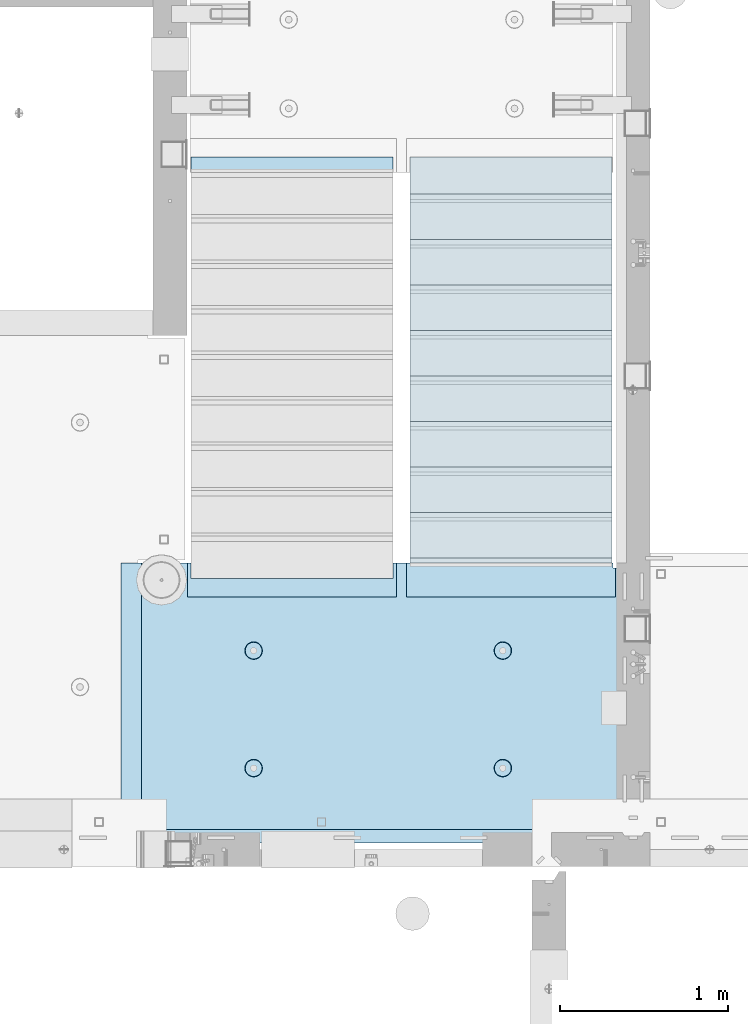
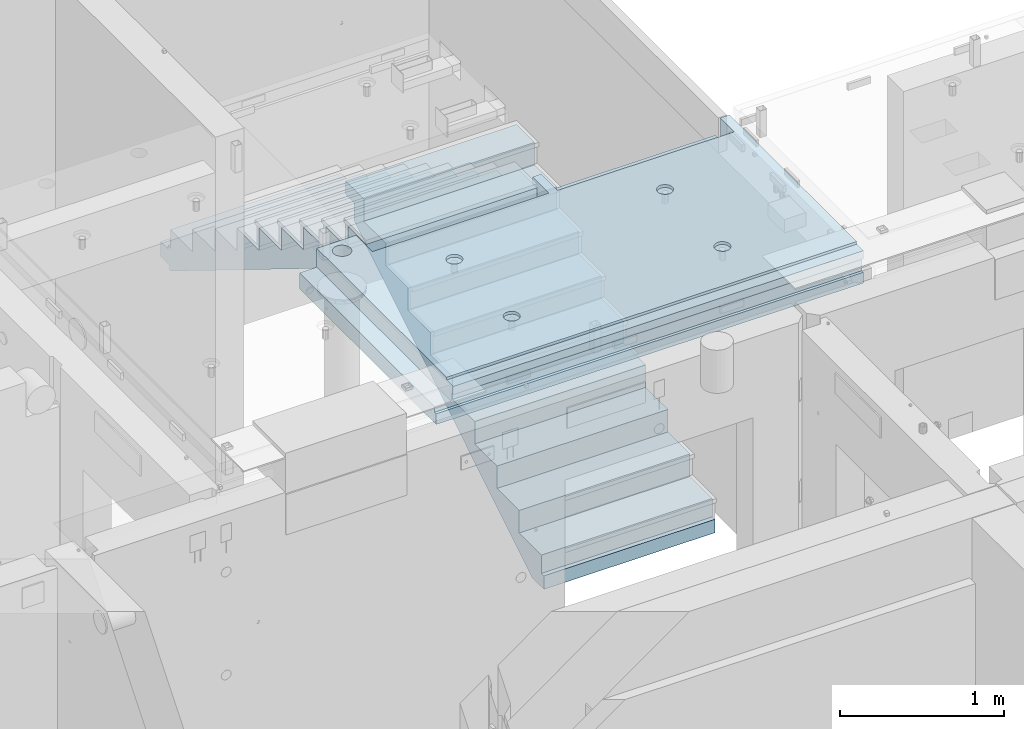
# One storey, part 149 of 264: 2 plates, 1 slab, 3 elements without a shape of their own.
"""IFC2X3 building model written with IfcOpenShell, lengths in millimetres."""

from ifc_helpers import new_model, si_unit, frame, origin_with_axes, place, context, subcontext, project, spatial, faceted_brep, material, type_object, element, aggregate, save


model = new_model("IFC2X3")

# Units and contexts
model_context = context("Model", 3, precision=1e-05, world=origin_with_axes())
body_context = subcontext(model_context, "Body", "Model", "MODEL_VIEW")
ifc_project = project(units=[si_unit("LENGTHUNIT", "METRE", prefix="MILLI"), si_unit("AREAUNIT", "SQUARE_METRE"), si_unit("VOLUMEUNIT", "CUBIC_METRE"), si_unit("MASSUNIT", "GRAM", prefix="KILO"), si_unit("TIMEUNIT", "SECOND"), si_unit("PLANEANGLEUNIT", "RADIAN"), si_unit("SOLIDANGLEUNIT", "STERADIAN"), si_unit("THERMODYNAMICTEMPERATUREUNIT", "DEGREE_CELSIUS"), si_unit("LUMINOUSINTENSITYUNIT", "LUMEN")], contexts=[model_context])

# Site, building, storey
site_placement = place(None, origin_with_axes())
site = spatial("IfcSite", under=ifc_project, at=site_placement, CompositionType="ELEMENT")
building_placement = place(site_placement, origin_with_axes())
building = spatial("IfcBuilding", under=site, at=building_placement, CompositionType="ELEMENT")
storey_placement = place(building_placement, origin_with_axes())
storey = spatial("IfcBuildingStorey", under=building, at=storey_placement, Name="K", CompositionType="ELEMENT", Elevation=0.0)

# Assembly, plate
assembly_1_placement = place(storey_placement, origin_with_axes())
assembly_1 = element("IfcElementAssembly", 1, at=assembly_1_placement, inside=storey, Name="E9", AssemblyPlace="NOTDEFINED", PredefinedType="NOTDEFINED")
ifc_material_1 = material(Name="Undefined/C32/40")
plate_type = type_object("IfcPlateType", PredefinedType="NOTDEFINED")
plate_1_placement = place(assembly_1_placement, frame((20285.0002457424, 19199.9998138874, 80260.0), z_axis=(0.0, -1.0, 0.0), x_axis=(0.0, 0.0, -1.0)))
plate_1 = element("IfcPlate", 2, at=plate_1_placement, type_object=plate_type, material=ifc_material_1, Name="E9", context=body_context, shape_type="Brep", body=[
    faceted_brep([(0.0, -600.0, 0.0), (0.0, -600.0, 30.0), (0.0, 600.0, 30.0), (0.0, 600.0, 0.0), (-136.699996948242, -600.0, 30.0), (-136.699996948242, 600.0, 30.0), (-136.699996948242, -600.0, 300.0), (-136.699996948242, 600.0, 300.0), (-303.399993896484, -600.0, 300.0), (-303.399993896484, 600.0, 300.0), (-303.399993896484, -600.0, 570.0), (-303.399993896484, 600.0, 570.0), (-470.100006103516, -600.0, 570.0), (-470.100006103516, 600.0, 570.0), (-470.100006103516, -600.0, 840.0), (-470.100006103516, 600.0, 840.0), (-636.799987792969, -600.0, 840.0), (-636.799987792969, 600.0, 840.0), (-636.799987792969, -600.0, 1110.0), (-636.799987792969, 600.0, 1110.0), (-803.5, -600.0, 1110.0), (-803.5, 600.0, 1110.0), (-803.5, -600.0, 1380.0), (-803.5, 600.0, 1380.0), (-970.200012207031, -600.0, 1380.0), (-970.200012207031, 600.0, 1380.0), (-970.200012207031, -600.0, 1650.0), (-970.200012207031, 600.0, 1650.0), (-1136.90002441406, -600.0, 1650.0), (-1136.90002441406, 600.0, 1650.0), (-1136.90002441406, -600.0, 1920.0), (-1136.90002441406, 600.0, 1920.0), (-1303.59997558594, -600.0, 1920.0), (-1303.59997558594, 600.0, 1920.0), (-1303.59997558594, -600.0, 2190.0), (-1303.59997558594, 600.0, 2190.0), (-1470.30004882813, -600.0, 2190.0), (-1470.30004882813, 600.0, 2190.0), (-1470.30004882813, -600.0, 2410.0), (-1470.30004882813, 600.0, 2410.0), (-1370.30004882813, -600.0, 2410.0), (-1370.30004882813, 600.0, 2410.0), (-1370.30004882813, -600.0, 2310.0), (-1370.30004882813, 600.0, 2310.0), (-1236.65991210938, -600.0, 2310.0), (-1236.65991210938, 600.0, 2310.0), (170.0, -600.0, 31.6665592193604), (170.0, 600.0, 31.6665592193604), (170.0, -600.0, 20.0), (170.0, 600.0, 20.0), (135.0, -600.0, 20.0), (135.0, 600.0, 20.0), (135.0, -600.0, -90.0), (135.0, 600.0, -90.0), (25.0, -600.0, -90.0), (25.0, 600.0, -90.0), (25.0, -600.0, 0.0), (25.0, 600.0, 0.0)], [[[0, 1, 2, 3]], [[1, 4, 5, 2]], [[4, 6, 7, 5]], [[6, 8, 9, 7]], [[8, 10, 11, 9]], [[10, 12, 13, 11]], [[12, 14, 15, 13]], [[14, 16, 17, 15]], [[16, 18, 19, 17]], [[18, 20, 21, 19]], [[20, 22, 23, 21]], [[22, 24, 25, 23]], [[24, 26, 27, 25]], [[26, 28, 29, 27]], [[28, 30, 31, 29]], [[30, 32, 33, 31]], [[32, 34, 35, 33]], [[34, 36, 37, 35]], [[36, 38, 39, 37]], [[38, 40, 41, 39]], [[40, 42, 43, 41]], [[42, 44, 45, 43]], [[44, 46, 47, 45]], [[46, 48, 49, 47]], [[48, 50, 51, 49]], [[50, 52, 53, 51]], [[52, 54, 55, 53]], [[54, 56, 57, 55]], [[56, 0, 3, 57]], [[5, 7, 9, 11, 13, 15, 17, 19, 21, 23, 25, 27, 29, 31, 33, 35, 37, 39, 41, 43, 45, 47, 49, 51, 53, 55, 57, 3, 2]], [[56, 54, 52, 50, 48, 46, 44, 42, 40, 38, 36, 34, 32, 30, 28, 26, 24, 22, 20, 18, 16, 14, 12, 10, 8, 6, 4, 1, 0]]]),
])
aggregate(assembly_1, [plate_1])

assembly_2_placement = place(storey_placement, origin_with_axes())
assembly_2 = element("IfcElementAssembly", 3, at=assembly_2_placement, inside=storey, Name="E9", AssemblyPlace="NOTDEFINED", PredefinedType="NOTDEFINED")
plate_2_placement = place(assembly_2_placement, frame((21585.002175553, 16880.0053086308, 78759.698366371), z_axis=(0.0, 1.0, 0.0), x_axis=(0.0, 0.0, -1.0)))
plate_2 = element("IfcPlate", 4, at=plate_2_placement, type_object=plate_type, material=ifc_material_1, Name="E9", context=body_context, shape_type="Brep", body=[
    faceted_brep([(0.0, -600.0, 0.0), (0.0, -600.0, 30.0), (0.0, 600.0, 30.0), (0.0, 600.0, 0.0), (-136.699996948242, -600.0, 30.0), (-136.699996948242, 600.0, 30.0), (-136.699996948242, -600.0, 300.0), (-136.699996948242, 600.0, 300.0), (-303.399993896484, -600.0, 300.0), (-303.399993896484, 600.0, 300.0), (-303.399993896484, -600.0, 570.0), (-303.399993896484, 600.0, 570.0), (-470.100006103516, -600.0, 570.0), (-470.100006103516, 600.0, 570.0), (-470.100006103516, -600.0, 840.0), (-470.100006103516, 600.0, 840.0), (-636.799987792969, -600.0, 840.0), (-636.799987792969, 600.0, 840.0), (-636.799987792969, -600.0, 1110.0), (-636.799987792969, 600.0, 1110.0), (-803.5, -600.0, 1110.0), (-803.5, 600.0, 1110.0), (-803.5, -600.0, 1380.0), (-803.5, 600.0, 1380.0), (-970.200012207031, -600.0, 1380.0), (-970.200012207031, 600.0, 1380.0), (-970.200012207031, -600.0, 1650.0), (-970.200012207031, 600.0, 1650.0), (-1136.90002441406, -600.0, 1650.0), (-1136.90002441406, 600.0, 1650.0), (-1136.90002441406, -600.0, 1920.0), (-1136.90002441406, 600.0, 1920.0), (-1303.59997558594, -600.0, 1920.0), (-1303.59997558594, 600.0, 1920.0), (-1303.59997558594, -600.0, 2190.0), (-1303.59997558594, 600.0, 2190.0), (-1470.30004882813, -600.0, 2190.0), (-1470.30004882813, 600.0, 2190.0), (-1470.30004882813, -600.0, 2410.0), (-1470.30004882813, 600.0, 2410.0), (-1370.30004882813, -600.0, 2410.0), (-1370.30004882813, 600.0, 2410.0), (-1370.30004882813, -600.0, 2310.0), (-1370.30004882813, 600.0, 2310.0), (-1236.65991210938, -600.0, 2310.0), (-1236.65991210938, 600.0, 2310.0), (100.0, -600.0, 145.043884277344), (100.0, 600.0, 145.043884277344), (100.0, -600.0, 0.0), (100.0, 600.0, 0.0)], [[[0, 1, 2, 3]], [[1, 4, 5, 2]], [[4, 6, 7, 5]], [[6, 8, 9, 7]], [[8, 10, 11, 9]], [[10, 12, 13, 11]], [[12, 14, 15, 13]], [[14, 16, 17, 15]], [[16, 18, 19, 17]], [[18, 20, 21, 19]], [[20, 22, 23, 21]], [[22, 24, 25, 23]], [[24, 26, 27, 25]], [[26, 28, 29, 27]], [[28, 30, 31, 29]], [[30, 32, 33, 31]], [[32, 34, 35, 33]], [[34, 36, 37, 35]], [[36, 38, 39, 37]], [[38, 40, 41, 39]], [[40, 42, 43, 41]], [[42, 44, 45, 43]], [[44, 46, 47, 45]], [[46, 48, 49, 47]], [[48, 0, 3, 49]], [[5, 7, 9, 11, 13, 15, 17, 19, 21, 23, 25, 27, 29, 31, 33, 35, 37, 39, 41, 43, 45, 47, 49, 3, 2]], [[48, 46, 44, 42, 40, 38, 36, 34, 32, 30, 28, 26, 24, 22, 20, 18, 16, 14, 12, 10, 8, 6, 4, 1, 0]]]),
])
aggregate(assembly_2, [plate_2])

# Assembly, slab
assembly_3_placement = place(storey_placement, origin_with_axes())
assembly_3 = element("IfcElementAssembly", 5, at=assembly_3_placement, inside=storey, AssemblyPlace="NOTDEFINED", PredefinedType="REINFORCEMENT_UNIT")
ifc_material_2 = material(Name="CONCRETE/C25/30")
slab_type = type_object("IfcSlabType", PredefinedType="NOTDEFINED")
slab_placement = place(assembly_3_placement, frame((22270.0159390845, 15220.0026483125, 81620.0), z_axis=(-0.999999999997437, -2.26400000064461e-06, 0.0), x_axis=(-1.19799915409591e-06, 0.999999999999282, 0.0)))
slab = element("IfcSlab", 6, at=slab_placement, type_object=slab_type, material=ifc_material_2, PredefinedType="FLOOR", context=body_context, shape_type="Brep", body=[
    faceted_brep([(1125.48886186239, -110.000000000015, 2260.89374658681), (1111.55041903891, -110.000000000015, 2253.79182922734), (1100.48878532136, -110.000000000015, 2242.73028873684), (1093.38675048894, -110.000000000015, 2228.79190576882), (1090.93951119383, -110.000000000015, 2213.34106636259), (1093.38662026918, -110.000000000015, 2197.89020633159), (1100.48853762865, -110.000000000015, 2183.95176350811), (1111.55007811915, -110.000000000015, 2172.89012979056), (1125.48846108717, -110.000000000015, 2165.78809495814), (1140.93930049339, -110.000000000015, 2163.34085566304), (1156.39016052439, -110.000000000015, 2165.78796473838), (1170.32860334787, -110.000000000015, 2172.88988209786), (1181.39023706543, -110.000000000015, 2183.95142258835), (1188.49227189785, -110.000000000015, 2197.88980555638), (1190.93951119295, -110.000000000015, 2213.3406449626), (1188.49240211761, -110.000000000015, 2228.7915049936), (1181.39048475813, -110.000000000015, 2242.72994781708), (1170.32894426763, -110.000000000015, 2253.79158153463), (1156.39056129961, -110.000000000015, 2260.89361636705), (1140.93972189339, -110.000000000015, 2263.34085566215), (1171.66447117308, -130.000000000015, 2171.05120148128), (1157.09246276671, -130.000000000015, 2163.62646969637), (1183.22890642325, -130.000000000015, 2182.6155392668), (1190.65376102078, -130.000000000015, 2197.187485097), (1193.21223846565, -130.000000000015, 2213.34063538532), (1190.65389715962, -130.000000000015, 2229.49380723591), (1183.22916537471, -130.000000000015, 2244.06581564228), (1171.66482758919, -130.000000000015, 2255.63025089245), (1157.09288175898, -130.000000000015, 2263.05510548998), (1140.93973147066, -130.000000000015, 2265.61358293486), (1124.78655962007, -130.000000000015, 2263.05524162882), (1110.2145512137, -130.000000000015, 2255.63050984392), (1098.65011596354, -130.000000000015, 2244.0661720584), (1091.22526136601, -130.000000000015, 2229.49422622819), (1088.66678392113, -130.000000000015, 2213.34107593987), (1091.22512522717, -130.000000000015, 2197.18790408927), (1098.64985701207, -130.000000000015, 2182.61589568291), (1110.21419479759, -130.000000000015, 2171.05146043274), (1124.7861406278, -130.000000000015, 2163.62660583521), (1140.93929091612, -130.000000000015, 2161.06812839033), (80.0042127926554, -130.000000000058, 2.18278728425503e-11), (80.0005811085466, -130.0, 2880.00325714382), (80.0005811085466, -110.000000000058, 2880.00325713216), (80.0042127926554, -110.000000000058, 1.81898940354586e-11), (0.00287564654718153, -110.000000081389, 2880.00331593842), (0.000610352206422249, -110.000000000058, 2700.0166015625), (0.0011602381728153, -110.000000000058, 590.016296386719), (-0.00164377339933708, -110.000000000058, 510.016937255856), (1.81898940354586e-12, -110.000000000058, 0.0), (0.00500251972698607, -49.9988643551042, 2880.00331592003), (0.000610352206422249, -49.9988643791585, 2700.0166015625), (0.0011602381728153, -49.9988643791585, 590.016296386719), (-0.00164377339933708, -49.9988643791585, 510.016937255856), (1.81898940354586e-12, -49.9988643791585, 0.0), (1660.00547821258, 9.99999999994179, 2880.00209580286), (1660.00598144532, 9.99999999994179, 3000.00268554688), (20.0057434080809, 9.99999999994179, 3000.00340914329), (20.005681128403, 9.99999999994179, 2880.00330120271), (0.0011602381728153, 130.0, 590.016296386719), (-0.00164377339933708, 130.0, 510.016937255856), (-0.00164377339933708, 50.0011356208415, 510.016937255856), (0.0011602381728153, 50.0011356208415, 590.016296386719), (0.000610352206422249, 130.0, 2700.0166015625), (0.000610352206422249, 50.0011356208415, 2700.0166015625), (0.00320434640525491, 130.0, 3000.00341796875), (0.00320434640525491, 50.0011356208415, 3000.00341796875), (1660.00598144532, 130.0, 3000.00268554688), (20.0057434059418, 50.0011356208415, 2999.99855711448), (1595.27464303854, -130.000000000044, 2711.47301343723), (1595.27464303854, 130.0, 2711.47301343723), (1578.5485309449, 130.0, 2702.95067473791), (1578.5485309449, -130.000000000044, 2702.95067473791), (1608.54857344758, -130.000000000044, 2724.74689207804), (1608.54857344758, 130.0, 2724.74689207804), (1617.07097737866, -130.000000000044, 2741.47297093443), (1617.07097737866, 130.0, 2741.47297093443), (1620.00762255593, -130.000000000044, 2760.0139848705), (1620.00762255593, 130.0, 2760.0139848705), (1617.07104968864, -130.000000000044, 2778.55501025935), (1617.07104968864, 130.0, 2778.55501025935), (1608.54871098933, -130.000000000044, 2795.281122353), (1608.54871098933, 130.0, 2795.281122353), (1595.27483234851, -130.000000000044, 2808.55505276204), (1595.27483234851, 130.0, 2808.55505276204), (1578.54875349212, -130.000000000044, 2817.07745669311), (1578.54875349212, 130.0, 2817.07745669311), (1560.00773955605, -130.000000000044, 2820.01410187039), (1560.00773955605, 130.0, 2820.01410187039), (1541.4667141672, -130.000000000044, 2817.07752900309), (1541.4667141672, 130.0, 2817.07752900309), (1524.74060207355, -130.000000000044, 2808.55519030378), (1524.74060207355, 130.0, 2808.55519030378), (1511.46667166452, -130.000000000044, 2795.28131166297), (1511.46667166452, 130.0, 2795.28131166297), (1502.94426773343, -130.000000000044, 2778.55523280658), (1502.94426773343, 130.0, 2778.55523280658), (1500.00762255616, -130.000000000044, 2760.0142188705), (1500.00762255616, 130.0, 2760.0142188705), (1502.94419542345, -130.000000000044, 2741.47319348165), (1502.94419542345, 130.0, 2741.47319348165), (1511.46653412277, -130.000000000044, 2724.74708138801), (1511.46653412277, 130.0, 2724.74708138801), (1524.74041276358, -130.000000000044, 2711.47315097897), (1524.74041276358, 130.0, 2711.47315097897), (1541.46649161997, -130.000000000044, 2702.95074704789), (1541.46649161997, 130.0, 2702.95074704789), (1560.00750555605, -130.000000000044, 2700.01410187062), (1560.00750555605, 130.0, 2700.01410187062), (0.0, 130.0, -1.81898940354586e-12), (1659.99373621813, 130.0, 80.0128438608808), (1629.99930931353, 130.0, 80.0129023416339), (1629.99915312915, 130.0, 4.22005541622639e-10), (1659.99373621844, 9.6963927030738, 80.012916818363), (1629.99930931353, 9.6963927030738, 80.0129023416339), (1629.99915312915, -130.0, -0.0816563740336278), (1629.99928003934, 9.6963927030738, 65.0096695056891), (1629.99928005723, -130.000000000029, 65.0096695056891), (20.0041864031919, -49.9988643791585, -0.0067402957174636), (20.0041864031919, 50.0011356208415, -0.0067402957174636), (1.81898940354586e-12, 50.0011356208415, 0.0), (20.005681128403, -49.9988643791585, 2880.00330122157), (1660.00547821258, -130.000000000058, 2880.00209580286), (1660.00432501575, 9.6963927030738, 2605.01144205537), (1459.9994895242, 9.6963927030738, 2605.0118320648), (1459.99707152063, 9.6963927030738, 1365.01000101247), (1659.999124962, 9.6963927030738, 1365.00961100846), (1660.00432501575, -130.000000000058, 2605.01144205537), (1459.9994895242, -130.000000000029, 2605.0118320648), (1459.99707152063, -130.000000000029, 1365.01000101247), (1659.999124962, -130.000000000029, 1365.00961100846), (1659.99887335454, -130.000000000029, 1305.01144206353), (1659.99887335454, 9.6963927030738, 1305.01144206353), (1459.9969545242, 9.6963927030738, 1305.01183206727), (1459.99453652063, 9.6963927030738, 65.0100010149399), (1459.9969545242, -130.000000000029, 1305.01183206727), (1459.99453652063, -130.000000000029, 65.0100010149399), (459.011804524533, -110.000000000015, 686.639394584807), (472.950215190385, -110.000000000015, 693.741375057478), (484.011798821171, -110.000000000015, 704.802965634939), (491.11377054052, -110.000000000015, 718.741380760835), (493.560939874198, -110.000000000015, 734.192231247995), (491.113760837387, -110.000000000015, 749.643080198333), (484.011780364715, -110.000000000015, 763.581490864184), (472.950189787254, -110.000000000015, 774.643074494968), (459.01177466136, -110.000000000015, 781.745046214317), (443.560924174199, -110.000000000015, 784.192215547995), (428.110075223865, -110.000000000015, 781.745036511187), (414.171664558011, -110.000000000015, 774.643056038512), (403.110080927225, -110.000000000015, 763.581465461055), (396.008109207876, -110.000000000015, 749.643050335155), (393.5609398742, -110.000000000015, 734.192199847996), (396.008118911011, -110.000000000015, 718.741350897661), (403.110099383681, -110.000000000015, 704.802940231806), (414.171689961144, -110.000000000015, 693.741356601022), (428.110105087038, -110.000000000015, 686.639384881673), (443.560955574198, -110.000000000015, 684.192215547999), (459.714116554094, -130.000000000015, 684.477902722843), (443.560956287836, -130.000000000015, 681.919488275271), (474.286091341124, -130.000000000015, 691.902700489729), (485.850474227853, -130.000000000015, 703.467090638893), (493.275262843534, -130.000000000015, 718.039070088693), (495.833667146922, -130.000000000015, 734.192231961631), (493.27525269935, -130.000000000015, 750.34539222789), (485.850454932464, -130.000000000015, 764.917367014921), (474.286064783302, -130.000000000015, 776.48174990165), (459.714085333502, -130.000000000015, 783.906538517334), (443.560923460562, -130.000000000015, 786.464942820723), (427.407763194304, -130.000000000015, 783.906528373147), (412.835788407272, -130.000000000015, 776.481730606265), (401.271405520543, -130.000000000015, 764.917340457101), (393.846616904862, -130.000000000015, 750.345361007297), (391.288212601474, -130.000000000015, 734.192199134359), (393.846627049048, -130.000000000015, 718.039038868101), (401.271424815932, -130.000000000015, 703.467064081069), (412.835814965094, -130.000000000015, 691.90268119434), (427.407794414894, -130.000000000015, 684.47789257866), (1125.48597751989, -110.000000000015, 781.743746589622), (1111.54753469641, -110.000000000015, 774.641829230146), (1100.48590097885, -110.000000000015, 763.580288739649), (1093.38386614644, -110.000000000015, 749.641905771627), (1090.93662685133, -110.000000000015, 734.191066365405), (1093.38373592667, -110.000000000015, 718.740206334405), (1100.48565328615, -110.000000000015, 704.801763510925), (1111.54719377665, -110.000000000015, 693.740129793372), (1125.48557674467, -110.000000000015, 686.638094960952), (1140.93641615089, -110.000000000015, 684.190855665849), (1156.38727618189, -110.000000000015, 686.637964741192), (1170.32571900537, -110.000000000015, 693.739882100668), (1181.38735272293, -110.000000000015, 704.801422591165), (1188.48938755535, -110.000000000015, 718.739805559188), (1190.93662685045, -110.000000000015, 734.190644965409), (1188.48951777511, -110.000000000015, 749.641504996409), (1181.38760041563, -110.000000000015, 763.57994781989), (1170.32605992513, -110.000000000015, 774.641581537442), (1156.38767695711, -110.000000000015, 781.743616369862), (1140.93683755089, -110.000000000015, 784.190855664965), (1157.08957842421, -130.000000000015, 684.476469699181), (1140.93640657362, -130.000000000015, 681.918128393143), (1171.66158683058, -130.000000000015, 691.901201484088), (1183.22602208075, -130.000000000015, 703.465539269608), (1190.65087667828, -130.000000000015, 718.037485099812), (1193.20935412316, -130.000000000015, 734.190635388135), (1190.65101281712, -130.000000000015, 750.343807238725), (1183.22628103221, -130.000000000015, 764.915815645094), (1171.66194324669, -130.000000000015, 776.480250895263), (1157.08999741648, -130.000000000015, 783.905105492791), (1140.93684712817, -130.000000000015, 786.463582937671), (1124.78367527757, -130.000000000015, 783.905241631634), (1110.2116668712, -130.000000000015, 776.480509846726), (1098.64723162104, -130.000000000015, 764.916172061206), (1091.22237702351, -130.000000000015, 750.344226230998), (1088.66389957863, -130.000000000015, 734.191075942679), (1091.22224088467, -130.000000000015, 718.037904092085), (1098.64697266957, -130.000000000015, 703.46589568572), (1110.21131045509, -130.000000000015, 691.901460435551), (1124.7832562853, -130.000000000015, 684.476605838023), (459.014688867032, -110.000000000015, 2165.789394582), (472.953099532886, -110.000000000015, 2172.89137505467), (484.014683163672, -110.000000000015, 2183.95296563213), (491.116654883021, -110.000000000015, 2197.89138075802), (493.563824216697, -110.000000000015, 2213.34223124518), (491.116645179885, -110.000000000015, 2228.79308019552), (484.014664707216, -110.000000000015, 2242.73149086137), (472.953074129753, -110.000000000015, 2253.79307449216), (459.014659003858, -110.000000000015, 2260.89504621151), (443.563808516699, -110.000000000015, 2263.34221554518), (428.112959566364, -110.000000000015, 2260.89503650838), (414.174548900512, -110.000000000015, 2253.7930560357), (403.112965269725, -110.000000000015, 2242.73146545824), (396.010993550377, -110.000000000015, 2228.79305033234), (393.563824216699, -110.000000000015, 2213.34219984519), (396.01100325351, -110.000000000015, 2197.89135089485), (403.11298372618, -110.000000000015, 2183.952940229), (414.174574303643, -110.000000000015, 2172.89135659821), (428.112989429537, -110.000000000015, 2165.78938487886), (443.563839916698, -110.000000000015, 2163.34221554519), (459.717000896593, -130.000000000015, 2163.62790272003), (443.563840630335, -130.000000000015, 2161.06948827246), (474.288975683625, -130.000000000015, 2171.05270048692), (485.853358570354, -130.000000000015, 2182.61709063608), (493.278147186034, -130.000000000015, 2197.18907008588), (495.836551489423, -130.000000000015, 2213.34223195882), (493.278137041849, -130.000000000015, 2229.49539222508), (485.853339274965, -130.000000000015, 2244.06736701211), (474.288949125803, -130.000000000015, 2255.63174989884), (459.716969676003, -130.000000000015, 2263.05653851452), (443.563807803061, -130.000000000015, 2265.61494281791), (427.410647536803, -130.000000000015, 2263.05652837034), (412.838672749773, -130.000000000015, 2255.63173060345), (401.274289863044, -130.000000000015, 2244.06734045429), (393.849501247363, -130.000000000015, 2229.49536100449), (391.291096943974, -130.000000000015, 2213.34219913155), (393.849511391547, -130.000000000015, 2197.18903886529), (401.274309158433, -130.000000000015, 2182.61706407826), (412.838699307595, -130.000000000015, 2171.05268119153), (427.410678757395, -130.000000000015, 2163.62789257585)], [[[0, 1, 2, 3, 4, 5, 6, 7, 8, 9, 10, 11, 12, 13, 14, 15, 16, 17, 18, 19]], [[20, 11, 10, 21]], [[22, 12, 11, 20]], [[23, 13, 12, 22]], [[24, 14, 13, 23]], [[25, 15, 14, 24]], [[26, 16, 15, 25]], [[27, 17, 16, 26]], [[28, 18, 17, 27]], [[29, 19, 18, 28]], [[30, 0, 19, 29]], [[31, 1, 0, 30]], [[32, 2, 1, 31]], [[33, 3, 2, 32]], [[34, 4, 3, 33]], [[35, 5, 4, 34]], [[36, 6, 5, 35]], [[37, 7, 6, 36]], [[38, 8, 7, 37]], [[39, 9, 8, 38]], [[21, 10, 9, 39]], [[40, 41, 42, 43]], [[43, 42, 44, 45, 46, 47, 48]], [[45, 44, 49, 50]], [[46, 45, 50, 51]], [[47, 46, 51, 52]], [[48, 47, 52, 53]], [[54, 55, 56, 57]], [[58, 59, 60, 61]], [[62, 58, 61, 63]], [[64, 62, 63, 65]], [[55, 66, 64, 65, 67, 56]], [[68, 69, 70, 71]], [[72, 73, 69, 68]], [[74, 75, 73, 72]], [[76, 77, 75, 74]], [[78, 79, 77, 76]], [[80, 81, 79, 78]], [[82, 83, 81, 80]], [[84, 85, 83, 82]], [[86, 87, 85, 84]], [[88, 89, 87, 86]], [[90, 91, 89, 88]], [[92, 93, 91, 90]], [[94, 95, 93, 92]], [[96, 97, 95, 94]], [[98, 99, 97, 96]], [[100, 101, 99, 98]], [[102, 103, 101, 100]], [[104, 105, 103, 102]], [[106, 107, 105, 104]], [[71, 70, 107, 106]], [[108, 59, 58, 62, 64, 66, 109, 110, 111], [69, 73, 75, 77, 79, 81, 83, 85, 87, 89, 91, 93, 95, 97, 99, 101, 103, 105, 107, 70]], [[110, 109, 112, 113]], [[114, 111, 110, 113, 115, 116]], [[40, 43, 48, 53, 117, 118, 119, 108, 111, 114]], [[59, 108, 119, 60]], [[118, 67, 65, 63, 61, 60, 119]], [[117, 120, 57, 56, 67, 118]], [[53, 52, 51, 50, 49, 120, 117]], [[44, 42, 41, 121, 54, 57, 120, 49]], [[122, 123, 124, 125]], [[126, 127, 123, 122]], [[128, 124, 123, 127]], [[129, 125, 124, 128]], [[109, 66, 55, 54, 121, 126, 122, 125, 129, 130, 131, 112]], [[113, 112, 131, 132, 133, 115]], [[130, 134, 132, 131]], [[135, 133, 132, 134]], [[116, 115, 133, 135]], [[136, 137, 138, 139, 140, 141, 142, 143, 144, 145, 146, 147, 148, 149, 150, 151, 152, 153, 154, 155]], [[156, 136, 155, 157]], [[158, 137, 136, 156]], [[159, 138, 137, 158]], [[160, 139, 138, 159]], [[161, 140, 139, 160]], [[162, 141, 140, 161]], [[163, 142, 141, 162]], [[164, 143, 142, 163]], [[165, 144, 143, 164]], [[166, 145, 144, 165]], [[167, 146, 145, 166]], [[168, 147, 146, 167]], [[169, 148, 147, 168]], [[170, 149, 148, 169]], [[171, 150, 149, 170]], [[172, 151, 150, 171]], [[173, 152, 151, 172]], [[174, 153, 152, 173]], [[175, 154, 153, 174]], [[157, 155, 154, 175]], [[176, 177, 178, 179, 180, 181, 182, 183, 184, 185, 186, 187, 188, 189, 190, 191, 192, 193, 194, 195]], [[196, 186, 185, 197]], [[198, 187, 186, 196]], [[199, 188, 187, 198]], [[200, 189, 188, 199]], [[201, 190, 189, 200]], [[202, 191, 190, 201]], [[203, 192, 191, 202]], [[204, 193, 192, 203]], [[205, 194, 193, 204]], [[206, 195, 194, 205]], [[207, 176, 195, 206]], [[208, 177, 176, 207]], [[209, 178, 177, 208]], [[210, 179, 178, 209]], [[211, 180, 179, 210]], [[212, 181, 180, 211]], [[213, 182, 181, 212]], [[214, 183, 182, 213]], [[215, 184, 183, 214]], [[197, 185, 184, 215]], [[216, 217, 218, 219, 220, 221, 222, 223, 224, 225, 226, 227, 228, 229, 230, 231, 232, 233, 234, 235]], [[236, 216, 235, 237]], [[238, 217, 216, 236]], [[239, 218, 217, 238]], [[240, 219, 218, 239]], [[241, 220, 219, 240]], [[242, 221, 220, 241]], [[243, 222, 221, 242]], [[244, 223, 222, 243]], [[245, 224, 223, 244]], [[246, 225, 224, 245]], [[247, 226, 225, 246]], [[248, 227, 226, 247]], [[249, 228, 227, 248]], [[250, 229, 228, 249]], [[251, 230, 229, 250]], [[252, 231, 230, 251]], [[253, 232, 231, 252]], [[254, 233, 232, 253]], [[255, 234, 233, 254]], [[237, 235, 234, 255]], [[134, 130, 129, 128, 127, 126, 121, 41, 40, 114, 116, 135], [37, 36, 35, 34, 33, 32, 31, 30, 29, 28, 27, 26, 25, 24, 23, 22, 20, 21, 39, 38], [254, 253, 252, 251, 250, 249, 248, 247, 246, 245, 244, 243, 242, 241, 240, 239, 238, 236, 237, 255], [214, 213, 212, 211, 210, 209, 208, 207, 206, 205, 204, 203, 202, 201, 200, 199, 198, 196, 197, 215], [174, 173, 172, 171, 170, 169, 168, 167, 166, 165, 164, 163, 162, 161, 160, 159, 158, 156, 157, 175], [102, 100, 98, 96, 94, 92, 90, 88, 86, 84, 82, 80, 78, 76, 74, 72, 68, 71, 106, 104]]]),
])
aggregate(assembly_3, [slab])

save(model, "model.ifc")
